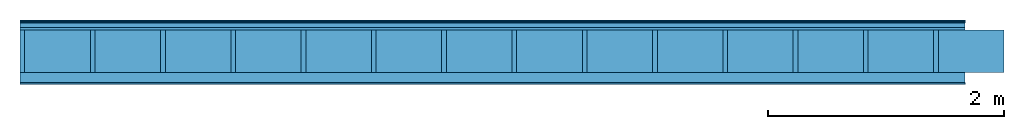
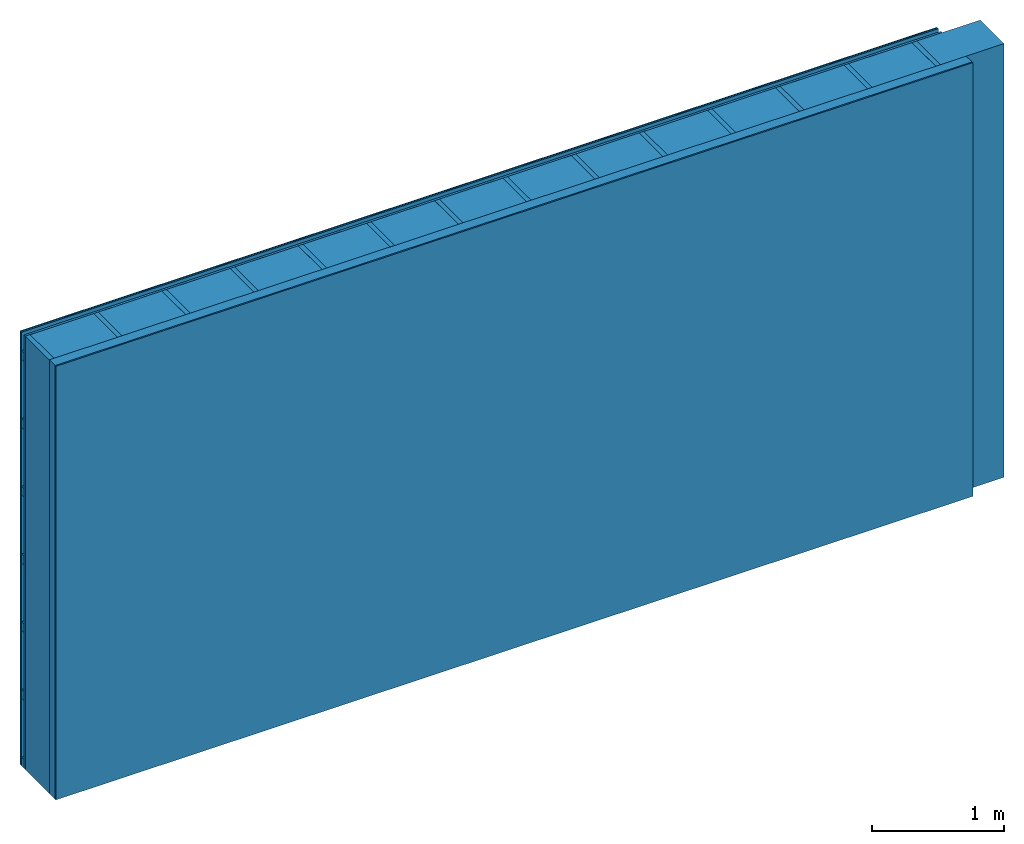
# One storey: 5 plates, 3 members, 1 element without a shape of its own.
"""IFC4 building model written with IfcOpenShell, lengths in metres."""

from ifc_helpers import new_model, si_unit, derived_unit, direction, frame, frame_2d, origin, origin_with_axes, place, context, project, spatial, rectangle, extrude, material, layer, layer_set, type_object, element, aggregate, save


model = new_model("IFC4")

# Units and contexts
plan_context = context("Plan", 3, precision=1e-05, world=origin(), true_north=direction((0.0, 1.0)))
model_context = context("Model", 3, precision=1e-05, world=origin(), true_north=direction((0.0, 1.0)))
ifc_project = project(units=[si_unit("LENGTHUNIT", "METRE"), derived_unit("SOUNDPRESSUREUNIT", [(si_unit("PRESSUREUNIT", "PASCAL", prefix="MICRO"), 0)]), si_unit("ENERGYUNIT", "JOULE", prefix="MEGA"), si_unit("MASSUNIT", "GRAM", prefix="KILO"), derived_unit("THERMALTRANSMITTANCEUNIT", [(si_unit("POWERUNIT", "WATT"), 1), (si_unit("AREAUNIT", "SQUARE_METRE"), -1), (si_unit("THERMODYNAMICTEMPERATUREUNIT", "KELVIN"), -1)]), derived_unit("AREADENSITYUNIT", [(si_unit("MASSUNIT", "GRAM", prefix="KILO"), 1), (si_unit("AREAUNIT", "SQUARE_METRE"), -1)]), derived_unit("USERDEFINED", [(si_unit("ENERGYUNIT", "JOULE", prefix="MEGA"), 1), (si_unit("AREAUNIT", "SQUARE_METRE"), -1)])], contexts=[plan_context, model_context])

# Site, building, storey
site = spatial("IfcSite", under=ifc_project)
building_placement = place(None, origin())
building = spatial("IfcBuilding", under=site, at=building_placement)
storey_placement = place(building_placement, origin())
storey = spatial("IfcBuildingStorey", under=building, at=storey_placement)

# Wall, members, plates
ifc_material_1 = material(Category="04.011")
ifc_layer_1 = layer(ifc_material_1, 0.01, Name="Surface 1")
ifc_material_2 = material(Name="mineral, cement-based building board", Category="03.003")
ifc_layer_2 = layer(ifc_material_2, 0.013, Name="Cover 1st layer")
ifc_layer_3 = layer(None, 0.04, Name="Battens / profiles (ventilation)")
ifc_material_3 = material(Category="10.009")
ifc_layer_4 = layer(ifc_material_3, 0.02, Name="outside 1st layer")
ifc_material_4 = material(Name="of the art")
ifc_layer_5 = layer(ifc_material_4, 0.0, Name="Bond")
ifc_layer_6 = layer(None, 0.36, Name="Support")
ifc_layer_7 = layer(ifc_material_4, 0.0, Name="Bond")
ifc_material_5 = material(Name="Solid timber panel")
ifc_layer_8 = layer(ifc_material_5, 0.087, Name="1st layer")
ifc_material_6 = material(Name="Plasterboard type A", Category="03.008")
ifc_layer_9 = layer(ifc_material_6, 0.0125, Name="Covering 1st layer")
ifc_material_7 = material(Name="joints", Category="04.017")
ifc_layer_10 = layer(ifc_material_7, 0.0, Name="Surface")
ifc_layer_set = layer_set([ifc_layer_1, ifc_layer_2, ifc_layer_3, ifc_layer_4, ifc_layer_5, ifc_layer_6, ifc_layer_7, ifc_layer_8, ifc_layer_9, ifc_layer_10])
wall_type = type_object("IfcWallType", Name="D0978", PredefinedType="NOTDEFINED", material=ifc_layer_set)
wall_placement = place(None, frame((0.0, 0.0, 0.0), z_axis=(0.0, -1.0, 0.0), x_axis=(1.0, 0.0, 0.0)))
wall = element("IfcWall", 1, at=wall_placement, inside=storey, type_object=wall_type, material=ifc_layer_set, Name="Wall #1")
ifc_material_8 = material()
member_1_placement = place(wall_placement, origin())
member_1 = element("IfcMember", 2, at=member_1_placement, material=ifc_material_8, Name="Battens / profiles (ventilation)", context=plan_context, shape_type="SweptSolid", body=[
    extrude(rectangle(XDim=0.08, YDim=0.04, at=frame_2d((0.04, 0.02), x_axis=(1.0, 0.0))), frame((0.0, 0.0, 0.023), z_axis=(1.0, 0.0, 0.0), x_axis=(0.0, 1.0, 0.0)), (0.0, 0.0, 1.0), 8.0),
    extrude(rectangle(XDim=0.08, YDim=0.04, at=frame_2d((0.04, 0.02), x_axis=(1.0, 0.0))), frame((0.0, 0.625, 0.023), z_axis=(1.0, 0.0, 0.0), x_axis=(0.0, 1.0, 0.0)), (0.0, 0.0, 1.0), 8.0),
    extrude(rectangle(XDim=0.08, YDim=0.04, at=frame_2d((0.04, 0.02), x_axis=(1.0, 0.0))), frame((0.0, 1.25, 0.023), z_axis=(1.0, 0.0, 0.0), x_axis=(0.0, 1.0, 0.0)), (0.0, 0.0, 1.0), 8.0),
    extrude(rectangle(XDim=0.08, YDim=0.04, at=frame_2d((0.04, 0.02), x_axis=(1.0, 0.0))), frame((0.0, 1.875, 0.023), z_axis=(1.0, 0.0, 0.0), x_axis=(0.0, 1.0, 0.0)), (0.0, 0.0, 1.0), 8.0),
    extrude(rectangle(XDim=0.08, YDim=0.04, at=frame_2d((0.04, 0.02), x_axis=(1.0, 0.0))), frame((0.0, 2.5, 0.023), z_axis=(1.0, 0.0, 0.0), x_axis=(0.0, 1.0, 0.0)), (0.0, 0.0, 1.0), 8.0),
    extrude(rectangle(XDim=0.08, YDim=0.04, at=frame_2d((0.04, 0.02), x_axis=(1.0, 0.0))), frame((0.0, 3.125, 0.023), z_axis=(1.0, 0.0, 0.0), x_axis=(0.0, 1.0, 0.0)), (0.0, 0.0, 1.0), 8.0),
    extrude(rectangle(XDim=0.08, YDim=0.04, at=frame_2d((0.04, 0.02), x_axis=(1.0, 0.0))), frame((0.0, 3.75, 0.023), z_axis=(1.0, 0.0, 0.0), x_axis=(0.0, 1.0, 0.0)), (0.0, 0.0, 1.0), 8.0),
])
ifc_material_9 = material()
member_2_placement = place(wall_placement, origin())
member_2 = element("IfcMember", 3, at=member_2_placement, material=ifc_material_9, Name="Support", context=plan_context, shape_type="SweptSolid", body=[
    extrude(rectangle(XDim=0.04, YDim=0.36, at=frame_2d((0.02, 0.18), x_axis=(1.0, 0.0))), frame((0.0, 4.0, 0.083), z_axis=(0.0, -1.0, 0.0), x_axis=(1.0, 0.0, 0.0)), (0.0, 0.0, 1.0), 4.0),
    extrude(rectangle(XDim=0.04, YDim=0.36, at=frame_2d((0.02, 0.18), x_axis=(1.0, 0.0))), frame((0.595, 4.0, 0.083), z_axis=(0.0, -1.0, 0.0), x_axis=(1.0, 0.0, 0.0)), (0.0, 0.0, 1.0), 4.0),
    extrude(rectangle(XDim=0.04, YDim=0.36, at=frame_2d((0.02, 0.18), x_axis=(1.0, 0.0))), frame((1.19, 4.0, 0.083), z_axis=(0.0, -1.0, 0.0), x_axis=(1.0, 0.0, 0.0)), (0.0, 0.0, 1.0), 4.0),
    extrude(rectangle(XDim=0.04, YDim=0.36, at=frame_2d((0.02, 0.18), x_axis=(1.0, 0.0))), frame((1.785, 4.0, 0.083), z_axis=(0.0, -1.0, 0.0), x_axis=(1.0, 0.0, 0.0)), (0.0, 0.0, 1.0), 4.0),
    extrude(rectangle(XDim=0.04, YDim=0.36, at=frame_2d((0.02, 0.18), x_axis=(1.0, 0.0))), frame((2.38, 4.0, 0.083), z_axis=(0.0, -1.0, 0.0), x_axis=(1.0, 0.0, 0.0)), (0.0, 0.0, 1.0), 4.0),
    extrude(rectangle(XDim=0.04, YDim=0.36, at=frame_2d((0.02, 0.18), x_axis=(1.0, 0.0))), frame((2.975, 4.0, 0.083), z_axis=(0.0, -1.0, 0.0), x_axis=(1.0, 0.0, 0.0)), (0.0, 0.0, 1.0), 4.0),
    extrude(rectangle(XDim=0.04, YDim=0.36, at=frame_2d((0.02, 0.18), x_axis=(1.0, 0.0))), frame((3.57, 4.0, 0.083), z_axis=(0.0, -1.0, 0.0), x_axis=(1.0, 0.0, 0.0)), (0.0, 0.0, 1.0), 4.0),
    extrude(rectangle(XDim=0.04, YDim=0.36, at=frame_2d((0.02, 0.18), x_axis=(1.0, 0.0))), frame((4.165, 4.0, 0.083), z_axis=(0.0, -1.0, 0.0), x_axis=(1.0, 0.0, 0.0)), (0.0, 0.0, 1.0), 4.0),
    extrude(rectangle(XDim=0.04, YDim=0.36, at=frame_2d((0.02, 0.18), x_axis=(1.0, 0.0))), frame((4.76, 4.0, 0.083), z_axis=(0.0, -1.0, 0.0), x_axis=(1.0, 0.0, 0.0)), (0.0, 0.0, 1.0), 4.0),
    extrude(rectangle(XDim=0.04, YDim=0.36, at=frame_2d((0.02, 0.18), x_axis=(1.0, 0.0))), frame((5.355, 4.0, 0.083), z_axis=(0.0, -1.0, 0.0), x_axis=(1.0, 0.0, 0.0)), (0.0, 0.0, 1.0), 4.0),
    extrude(rectangle(XDim=0.04, YDim=0.36, at=frame_2d((0.02, 0.18), x_axis=(1.0, 0.0))), frame((5.95, 4.0, 0.083), z_axis=(0.0, -1.0, 0.0), x_axis=(1.0, 0.0, 0.0)), (0.0, 0.0, 1.0), 4.0),
    extrude(rectangle(XDim=0.04, YDim=0.36, at=frame_2d((0.02, 0.18), x_axis=(1.0, 0.0))), frame((6.545, 4.0, 0.083), z_axis=(0.0, -1.0, 0.0), x_axis=(1.0, 0.0, 0.0)), (0.0, 0.0, 1.0), 4.0),
    extrude(rectangle(XDim=0.04, YDim=0.36, at=frame_2d((0.02, 0.18), x_axis=(1.0, 0.0))), frame((7.14, 4.0, 0.083), z_axis=(0.0, -1.0, 0.0), x_axis=(1.0, 0.0, 0.0)), (0.0, 0.0, 1.0), 4.0),
    extrude(rectangle(XDim=0.04, YDim=0.36, at=frame_2d((0.02, 0.18), x_axis=(1.0, 0.0))), frame((7.735, 4.0, 0.083), z_axis=(0.0, -1.0, 0.0), x_axis=(1.0, 0.0, 0.0)), (0.0, 0.0, 1.0), 4.0),
])
ifc_material_10 = material()
member_3_placement = place(wall_placement, origin())
member_3 = element("IfcMember", 4, at=member_3_placement, material=ifc_material_10, Name="Cavity", context=plan_context, shape_type="SweptSolid", body=[
    extrude(rectangle(XDim=0.555, YDim=0.36, at=frame_2d((0.2775, 0.18), x_axis=(1.0, 0.0))), frame((0.04, 4.0, 0.083), z_axis=(0.0, -1.0, 0.0), x_axis=(1.0, 0.0, 0.0)), (0.0, 0.0, 1.0), 4.0),
    extrude(rectangle(XDim=0.555, YDim=0.36, at=frame_2d((0.2775, 0.18), x_axis=(1.0, 0.0))), frame((0.635, 4.0, 0.083), z_axis=(0.0, -1.0, 0.0), x_axis=(1.0, 0.0, 0.0)), (0.0, 0.0, 1.0), 4.0),
    extrude(rectangle(XDim=0.555, YDim=0.36, at=frame_2d((0.2775, 0.18), x_axis=(1.0, 0.0))), frame((1.23, 4.0, 0.083), z_axis=(0.0, -1.0, 0.0), x_axis=(1.0, 0.0, 0.0)), (0.0, 0.0, 1.0), 4.0),
    extrude(rectangle(XDim=0.555, YDim=0.36, at=frame_2d((0.2775, 0.18), x_axis=(1.0, 0.0))), frame((1.825, 4.0, 0.083), z_axis=(0.0, -1.0, 0.0), x_axis=(1.0, 0.0, 0.0)), (0.0, 0.0, 1.0), 4.0),
    extrude(rectangle(XDim=0.555, YDim=0.36, at=frame_2d((0.2775, 0.18), x_axis=(1.0, 0.0))), frame((2.42, 4.0, 0.083), z_axis=(0.0, -1.0, 0.0), x_axis=(1.0, 0.0, 0.0)), (0.0, 0.0, 1.0), 4.0),
    extrude(rectangle(XDim=0.555, YDim=0.36, at=frame_2d((0.2775, 0.18), x_axis=(1.0, 0.0))), frame((3.015, 4.0, 0.083), z_axis=(0.0, -1.0, 0.0), x_axis=(1.0, 0.0, 0.0)), (0.0, 0.0, 1.0), 4.0),
    extrude(rectangle(XDim=0.555, YDim=0.36, at=frame_2d((0.2775, 0.18), x_axis=(1.0, 0.0))), frame((3.61, 4.0, 0.083), z_axis=(0.0, -1.0, 0.0), x_axis=(1.0, 0.0, 0.0)), (0.0, 0.0, 1.0), 4.0),
    extrude(rectangle(XDim=0.555, YDim=0.36, at=frame_2d((0.2775, 0.18), x_axis=(1.0, 0.0))), frame((4.205, 4.0, 0.083), z_axis=(0.0, -1.0, 0.0), x_axis=(1.0, 0.0, 0.0)), (0.0, 0.0, 1.0), 4.0),
    extrude(rectangle(XDim=0.555, YDim=0.36, at=frame_2d((0.2775, 0.18), x_axis=(1.0, 0.0))), frame((4.8, 4.0, 0.083), z_axis=(0.0, -1.0, 0.0), x_axis=(1.0, 0.0, 0.0)), (0.0, 0.0, 1.0), 4.0),
    extrude(rectangle(XDim=0.555, YDim=0.36, at=frame_2d((0.2775, 0.18), x_axis=(1.0, 0.0))), frame((5.395, 4.0, 0.083), z_axis=(0.0, -1.0, 0.0), x_axis=(1.0, 0.0, 0.0)), (0.0, 0.0, 1.0), 4.0),
    extrude(rectangle(XDim=0.555, YDim=0.36, at=frame_2d((0.2775, 0.18), x_axis=(1.0, 0.0))), frame((5.99, 4.0, 0.083), z_axis=(0.0, -1.0, 0.0), x_axis=(1.0, 0.0, 0.0)), (0.0, 0.0, 1.0), 4.0),
    extrude(rectangle(XDim=0.555, YDim=0.36, at=frame_2d((0.2775, 0.18), x_axis=(1.0, 0.0))), frame((6.585, 4.0, 0.083), z_axis=(0.0, -1.0, 0.0), x_axis=(1.0, 0.0, 0.0)), (0.0, 0.0, 1.0), 4.0),
    extrude(rectangle(XDim=0.555, YDim=0.36, at=frame_2d((0.2775, 0.18), x_axis=(1.0, 0.0))), frame((7.18, 4.0, 0.083), z_axis=(0.0, -1.0, 0.0), x_axis=(1.0, 0.0, 0.0)), (0.0, 0.0, 1.0), 4.0),
    extrude(rectangle(XDim=0.555, YDim=0.36, at=frame_2d((0.2775, 0.18), x_axis=(1.0, 0.0))), frame((7.775, 4.0, 0.083), z_axis=(0.0, -1.0, 0.0), x_axis=(1.0, 0.0, 0.0)), (0.0, 0.0, 1.0), 4.0),
])
plate_1_placement = place(wall_placement, origin())
plate_1 = element("IfcPlate", 5, at=plate_1_placement, material=ifc_material_1, Name="Surface 1", context=plan_context, shape_type="SweptSolid", body=[
    extrude(rectangle(XDim=8.0, YDim=4.0, at=frame_2d((4.0, 2.0), x_axis=(1.0, 0.0))), origin_with_axes(), (0.0, 0.0, 1.0), 0.01),
])
plate_2_placement = place(wall_placement, origin())
plate_2 = element("IfcPlate", 6, at=plate_2_placement, material=ifc_material_2, Name="Cover 1st layer", context=plan_context, shape_type="SweptSolid", body=[
    extrude(rectangle(XDim=8.0, YDim=4.0, at=frame_2d((4.0, 2.0), x_axis=(1.0, 0.0))), frame((0.0, 0.0, 0.01), z_axis=(0.0, 0.0, 1.0), x_axis=(1.0, 0.0, 0.0)), (0.0, 0.0, 1.0), 0.013),
])
plate_3_placement = place(wall_placement, origin())
plate_3 = element("IfcPlate", 7, at=plate_3_placement, material=ifc_material_3, Name="outside 1st layer", context=plan_context, shape_type="SweptSolid", body=[
    extrude(rectangle(XDim=8.0, YDim=4.0, at=frame_2d((4.0, 2.0), x_axis=(1.0, 0.0))), frame((0.0, 0.0, 0.063), z_axis=(0.0, 0.0, 1.0), x_axis=(1.0, 0.0, 0.0)), (0.0, 0.0, 1.0), 0.02),
])
plate_4_placement = place(wall_placement, origin())
plate_4 = element("IfcPlate", 8, at=plate_4_placement, material=ifc_material_5, Name="1st layer", context=plan_context, shape_type="SweptSolid", body=[
    extrude(rectangle(XDim=8.0, YDim=4.0, at=frame_2d((4.0, 2.0), x_axis=(1.0, 0.0))), frame((0.0, 0.0, 0.443), z_axis=(0.0, 0.0, 1.0), x_axis=(1.0, 0.0, 0.0)), (0.0, 0.0, 1.0), 0.087),
])
plate_5_placement = place(wall_placement, origin())
plate_5 = element("IfcPlate", 9, at=plate_5_placement, material=ifc_material_6, Name="Covering 1st layer", context=plan_context, shape_type="SweptSolid", body=[
    extrude(rectangle(XDim=8.0, YDim=4.0, at=frame_2d((4.0, 2.0), x_axis=(1.0, 0.0))), frame((0.0, 0.0, 0.53), z_axis=(0.0, 0.0, 1.0), x_axis=(1.0, 0.0, 0.0)), (0.0, 0.0, 1.0), 0.0125),
])
aggregate(wall, [plate_1, plate_2, member_1, plate_3, member_2, member_3, plate_4, plate_5])

save(model, "model.ifc")
